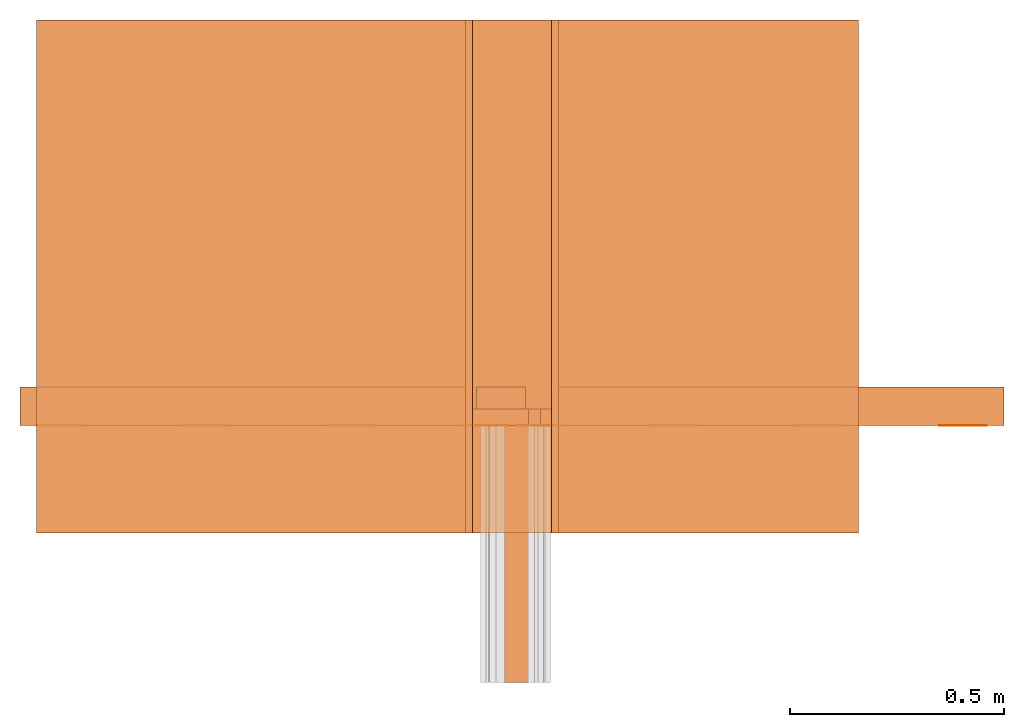
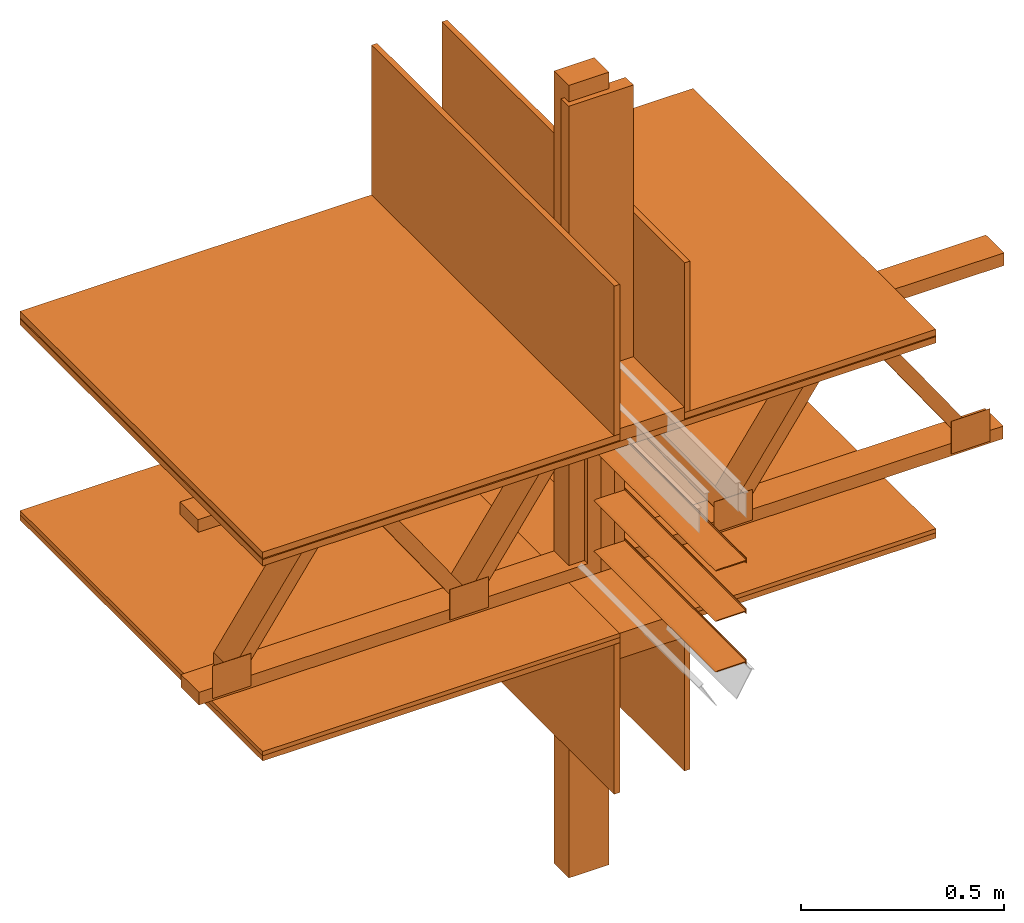
# One storey, part 1 of 2: 17 proxies.
"""IFC2X3 building model written with IfcOpenShell, lengths in metres."""

import ifcopenshell
import ifcopenshell.guid

model = None  # the IFC model being written
_history = None  # IfcOwnerHistory: only IFC2X3 demands one
_inside = {}  # id of a spatial element -> (the spatial element, [elements in it])
_under = {}  # id of a project, library or spatial element -> (it, [spatial elements below it])
_declared = {}  # id of a project -> (the project, [libraries it declares])
_typed = {}  # id of a type object -> (the type object, [elements of that type])
_made_of = {}  # id of a material, layer set ... -> (it, [elements and type objects made of it])


def new_model(schema):
    """Start an empty IFC model of exactly this schema.

    Asked for "IFC4X3", IfcOpenShell would pick the latest addendum, in which some entities
    have other attributes; the version numbers below select the first issue.
    IFC2X3 requires an IfcOwnerHistory on every rooted entity: one is made here for all.
    """
    global model, _history
    if schema == "IFC4X3":
        model = ifcopenshell.file(schema_version=(4, 3, 0, 0))
    else:
        model = ifcopenshell.file(schema=schema)
    _inside.clear()
    _under.clear()
    _declared.clear()
    _typed.clear()
    _made_of.clear()
    _history = None
    if model.schema == "IFC2X3":
        org = make("IfcOrganization", Name="unknown")
        user = make(
            "IfcPersonAndOrganization",
            ThePerson=make("IfcPerson", FamilyName="unknown"),
            TheOrganization=org,
        )
        app = make(
            "IfcApplication",
            ApplicationDeveloper=org,
            Version="unknown",
            ApplicationFullName="unknown",
            ApplicationIdentifier="unknown",
        )
        _history = make(
            "IfcOwnerHistory",
            OwningUser=user,
            OwningApplication=app,
            ChangeAction="ADDED",
            CreationDate=0,
        )
    return model


def make(cls, **values):
    """One entity of the class cls with the attributes given. An attribute that is None is left unset."""
    return model.create_entity(
        cls, **{name: value for name, value in values.items() if value is not None}
    )


def rooted(cls, **values):
    """An entity with a GlobalId (a new one), such as an element, a storey or a relation."""
    return make(cls, GlobalId=ifcopenshell.guid.new(), OwnerHistory=_history, **values)


def si_unit(unit_type, name, prefix=None):
    """IfcSIUnit, for example si_unit("LENGTHUNIT", "METRE", prefix="MILLI")."""
    return make("IfcSIUnit", UnitType=unit_type, Prefix=prefix, Name=name)


def assignment(units):
    """IfcUnitAssignment: the units of a project."""
    return None if units is None else make("IfcUnitAssignment", Units=units)


def point(xyz):
    """IfcCartesianPoint."""
    return None if xyz is None else make("IfcCartesianPoint", Coordinates=xyz)


def direction(xyz):
    """IfcDirection."""
    return None if xyz is None else make("IfcDirection", DirectionRatios=xyz)


def frame(location, z_axis=None, x_axis=None):
    """IfcAxis2Placement3D, a coordinate frame: its origin and axes. An axis left out is left unset."""
    return make(
        "IfcAxis2Placement3D",
        Location=point(location),
        Axis=direction(z_axis),
        RefDirection=direction(x_axis),
    )


def frame_2d(location, x_axis=None):
    """IfcAxis2Placement2D, a coordinate frame in the plane: its origin and x axis."""
    return make(
        "IfcAxis2Placement2D", Location=point(location), RefDirection=direction(x_axis)
    )


def origin_with_axes():
    """The frame at (0, 0, 0) with the z axis (0, 0, 1) and the x axis (1, 0, 0) written out."""
    return frame((0.0, 0.0, 0.0), z_axis=(0.0, 0.0, 1.0), x_axis=(1.0, 0.0, 0.0))


def place(relative_to, where):
    """IfcLocalPlacement: puts the frame where relative to a parent placement (None: the world)."""
    return make(
        "IfcLocalPlacement", PlacementRelTo=relative_to, RelativePlacement=where
    )


def context(
    kind, dimensions, precision=None, world=None, true_north=None, identifier=None
):
    """IfcGeometricRepresentationContext, for example the 3D "Model" context."""
    return make(
        "IfcGeometricRepresentationContext",
        ContextIdentifier=identifier,
        ContextType=kind,
        CoordinateSpaceDimension=dimensions,
        Precision=precision,
        WorldCoordinateSystem=world,
        TrueNorth=true_north,
    )


def subcontext(parent, identifier, kind, view, scale=None):
    """IfcGeometricRepresentationSubContext, for example "Body" below "Model"."""
    return make(
        "IfcGeometricRepresentationSubContext",
        ContextIdentifier=identifier,
        ContextType=kind,
        ParentContext=parent,
        TargetScale=scale,
        TargetView=view,
    )


def project(units=None, contexts=None):
    """IfcProject with its units and contexts."""
    return rooted(
        "IfcProject",
        Name="project",
        RepresentationContexts=contexts,
        UnitsInContext=assignment(units),
    )


def spatial(cls, under=None, at=None, **own):
    """A site, building, storey or space (cls), placed at a placement, below another one or the project."""
    s = rooted(cls, ObjectPlacement=at, **own)
    if under is not None:
        _under.setdefault(under.id(), (under, []))[1].append(s)
    return s


def faces_of(points, faces, orient=None, outer=None):
    """IfcFace entities. A face is a list of loops; a loop is a list of indices into points, from 0.

    orient and outer hold one flag for each loop. By default every Orientation is true, the
    first loop of a face is its IfcFaceOuterBound and the others are IfcFaceBound.
    """
    made = []
    for i, loops in enumerate(faces):
        bounds = []
        for j, loop in enumerate(loops):
            is_outer = j == 0 if outer is None else outer[i][j]
            bounds.append(
                make(
                    "IfcFaceOuterBound" if is_outer else "IfcFaceBound",
                    Bound=make("IfcPolyLoop", Polygon=[points[k] for k in loop]),
                    Orientation=True if orient is None else orient[i][j],
                )
            )
        made.append(make("IfcFace", Bounds=bounds))
    return made


def faceted_brep(points, faces, orient=None, outer=None, voids=None):
    """IfcFacetedBrep: a solid bounded by flat faces; with voids (closed shells), ...WithVoids."""
    shared = [point(p) for p in points]
    hull = make("IfcClosedShell", CfsFaces=faces_of(shared, faces, orient, outer))
    if voids is None:
        return make("IfcFacetedBrep", Outer=hull)
    return make(
        "IfcFacetedBrepWithVoids",
        Outer=hull,
        Voids=[
            make(cls, CfsFaces=faces_of(shared, fs, o, b)) for cls, fs, o, b in voids
        ],
    )


def shape(context_of_items, identifier, shape_type, items):
    """IfcShapeRepresentation: the items that make up one representation, for example the "Body"."""
    return make(
        "IfcShapeRepresentation",
        ContextOfItems=context_of_items,
        RepresentationIdentifier=identifier,
        RepresentationType=shape_type,
        Items=items,
    )


def made_of(thing, what):
    """Note that an element or type object is made of a material, layer set ...; save() writes the relation."""
    if what is not None:
        _made_of.setdefault(what.id(), (what, []))[1].append(thing)
    return thing


def element(
    cls,
    number,
    at=None,
    inside=None,
    cuts=None,
    type_object=None,
    material=None,
    context=None,
    identifier="Body",
    shape_type=None,
    held_by="IfcProductDefinitionShape",
    body=None,
    shapes=None,
    **own,
):
    """One element of the class cls, such as IfcWall. Its Tag is "e" and its number.

    at: its placement. inside: the storey or other place that contains it. cuts: it is an
    opening in that element (IfcRelVoidsElement). A single representation is given by context,
    identifier, shape_type and body (its items); several are given by shapes. held_by: the class
    of the entity that holds the representations. save() writes the other relations.
    """
    e = rooted(cls, Tag="e%d" % number, ObjectPlacement=at, **own)
    if body is not None:
        shapes = [shape(context, identifier, shape_type, body)]
    if shapes is not None:
        e.Representation = make(held_by, Representations=shapes)
    if inside is not None:
        _inside.setdefault(inside.id(), (inside, []))[1].append(e)
    if cuts is not None:
        rooted(
            "IfcRelVoidsElement", RelatingBuildingElement=cuts, RelatedOpeningElement=e
        )
    if type_object is not None:
        _typed.setdefault(type_object.id(), (type_object, []))[1].append(e)
    return made_of(e, material)


def aggregate(whole, parts):
    """IfcRelAggregates: a whole, such as a stair, and the parts it consists of."""
    return rooted("IfcRelAggregates", RelatingObject=whole, RelatedObjects=parts)


def save(model, path):
    """Write the relations noted so far, then the file.

    IfcRelAggregates (storeys below a building ...), IfcRelContainedInSpatialStructure (elements
    in a storey), IfcRelDefinesByType, IfcRelAssociatesMaterial and IfcRelDeclares: one each for
    every whole, place, type object, material and project.
    """
    for whole, parts in _under.values():
        aggregate(whole, parts)
    for where, things in _inside.values():
        rooted(
            "IfcRelContainedInSpatialStructure",
            RelatedElements=things,
            RelatingStructure=where,
        )
    for kind, things in _typed.values():
        rooted("IfcRelDefinesByType", RelatedObjects=things, RelatingType=kind)
    for what, things in _made_of.values():
        rooted("IfcRelAssociatesMaterial", RelatedObjects=things, RelatingMaterial=what)
    for by, libraries in _declared.values():
        rooted("IfcRelDeclares", RelatingContext=by, RelatedDefinitions=libraries)
    model.write(path)


model = new_model("IFC2X3")

# Units and contexts
model_context = context("Model", 3, precision=1e-05, world=origin_with_axes())
plan_context = context("Plan", 2, precision=1e-05, world=frame_2d((0.0, 0.0, 0.0), x_axis=(1.0, 0.0, 0.0)))
body_context = subcontext(model_context, "Body", "Model", "MODEL_VIEW")
ifc_project = project(units=[si_unit("AREAUNIT", "SQUARE_METRE"), si_unit("VOLUMEUNIT", "CUBIC_METRE"), si_unit("LENGTHUNIT", "METRE")], contexts=[model_context, plan_context])

# Site, building, storey
site_placement = place(None, origin_with_axes())
site = spatial("IfcSite", under=ifc_project, at=site_placement, CompositionType="ELEMENT")
building_placement = place(site_placement, origin_with_axes())
building = spatial("IfcBuilding", under=site, at=building_placement, Name="Building", CompositionType="ELEMENT")
storey_placement = place(building_placement, origin_with_axes())
storey = spatial("IfcBuildingStorey", under=building, at=storey_placement, Name="Storey", CompositionType="ELEMENT")

# Proxies
proxy_1_placement = place(storey_placement, frame((1.87213277816772, 0.454421997070312, -0.0896223783493042), z_axis=(0.0, 0.0, 1.0), x_axis=(1.0, 0.0, 0.0)))
element("IfcBuildingElementProxy", 1, at=proxy_1_placement, inside=storey, Name="Generic Models 840:Generic Models 1:245", context=body_context, shape_type="Brep", body=[
    faceted_brep([(0.0, 0.0725396424531937, 2.38604950904846), (0.0, 0.0725396424531937, 0.0), (0.0, 1.52378110129803e-14, 0.0), (0.0, 1.52378110129803e-14, 2.38604950904846), (0.11429999768734, 1.52378110129803e-14, 0.0), (0.11429999768734, 0.0725396424531937, 0.0), (0.11429999768734, 1.52378110129803e-14, 2.38604950904846), (0.11429999768734, 0.0725396424531937, 2.38604950904846)], [[[0, 1, 2, 3]], [[4, 2, 1, 5]], [[3, 2, 4, 6]], [[0, 7, 5, 1]], [[3, 6, 7, 0]], [[4, 5, 7, 6]]]),
])
proxy_2_placement = place(storey_placement, frame((0.845521450042725, 0.18644905090332, 1.37181675434113), z_axis=(0.0, 0.0, 1.0), x_axis=(1.0, 0.0, 0.0)))
element("IfcBuildingElementProxy", 2, at=proxy_2_placement, inside=storey, Name="Generic Models 841:Generic Models 1:245", context=body_context, shape_type="Brep", body=[
    faceted_brep([(-1.44328982613359e-15, 1.19659399986267, 0.0190500002354383), (-1.44328982613359e-15, 1.19659399986267, 0.0), (-1.44328982613359e-15, 3.10862446895044e-15, 0.0), (-1.44328982613359e-15, 3.10862446895044e-15, 0.0190500002354383), (1.91697382926941, 3.10862446895044e-15, 0.0), (1.91697382926941, 1.19659399986267, 0.0), (1.91697382926941, 3.10862446895044e-15, 0.0190500002354383), (1.91697382926941, 1.19659399986267, 0.0190500002354383)], [[[0, 1, 2, 3]], [[4, 2, 1, 5]], [[3, 2, 4, 6]], [[0, 7, 5, 1]], [[3, 6, 7, 0]], [[6, 4, 5, 7]]]),
])
proxy_3_placement = place(storey_placement, frame((1.8625807762146, 0.43806266784668, 1.42896664142609), z_axis=(0.0, 0.0, 1.0), x_axis=(1.0, 0.0, 0.0)))
element("IfcBuildingElementProxy", 3, at=proxy_3_placement, inside=storey, Name="Generic Models 842:Generic Models 1:245", context=body_context, shape_type="Brep", body=[
    faceted_brep([(3.47638584585752e-14, 0.0381000004708767, 0.0), (3.47638584585752e-14, 1.76941794549634e-15, 0.0), (3.47638584585752e-14, 1.76941794549634e-15, 0.817955911159515), (3.47638584585752e-14, 0.0381000004708767, 0.817955911159515), (0.184149980545044, 1.76941794549634e-15, 0.0), (0.184149980545044, 0.0381000004708767, 0.0), (0.184149980545044, 1.76941794549634e-15, 0.817955911159515), (0.184149980545044, 0.0381000004708767, 0.817955911159515)], [[[0, 1, 2, 3]], [[4, 1, 0, 5]], [[2, 1, 4, 6]], [[7, 5, 0, 3]], [[2, 6, 7, 3]], [[4, 5, 7, 6]]]),
])
proxy_4_placement = place(storey_placement, frame((1.8625807762146, 0.18644905090332, 1.39086735248566), z_axis=(0.0, 0.0, 1.0), x_axis=(-1.62920684942947e-07, 1.0, 0.0)))
element("IfcBuildingElementProxy", 4, at=proxy_4_placement, inside=storey, Name="Generic Models 843:Generic Models 1:245", context=body_context, shape_type="Brep", body=[
    faceted_brep([(1.19659399986267, -3.47638584585752e-14, 0.0381000004708767), (1.19659399986267, -3.47638584585752e-14, 0.0), (1.44328982613359e-15, -3.47638584585752e-14, 0.0), (1.44328982613359e-15, -3.47638584585752e-14, 0.0381000004708767), (1.19659399986267, -0.184149980545044, 0.0381000004708767), (1.19659399986267, -0.184149980545044, 0.0), (1.44328982613359e-15, -0.184149980545044, 0.0), (1.44328982613359e-15, -0.184149980545044, 0.0381000004708767)], [[[0, 1, 2, 3]], [[4, 5, 1, 0]], [[3, 2, 6, 7]], [[7, 4, 0, 3]], [[2, 1, 5, 6]], [[7, 6, 5, 4]]]),
])
proxy_5_placement = place(storey_placement, frame((1.9631667137146, 0.437217712402344, 0.819366574287415), z_axis=(0.0, 0.0, 1.0), x_axis=(1.0, 0.0, 0.0)))
element("IfcBuildingElementProxy", 5, at=proxy_5_placement, inside=storey, Name="Generic Models 844:Generic Models 1:245", context=body_context, shape_type="Brep", body=[
    faceted_brep([(-1.52655679120849e-16, 4.05437402400954e-16, 0.54610002040863), (0.110011510550976, 4.05437402400954e-16, 0.54610002040863), (0.110011510550976, 0.000844365218654275, 0.54610002040863), (-1.52655679120849e-16, 0.000844365218654275, 0.54610002040863), (-1.52655679120849e-16, 0.000844365218654275, 0.45427468419075), (-1.52655679120849e-16, 4.05437402400954e-16, 0.45427468419075), (0.42253166437149, 1.48741696043286e-15, 0.0), (0.42253166437149, 0.000844365218654275, 0.0), (0.42253166437149, 0.000844365218654275, 0.0918253213167191), (0.42253166437149, 1.48741696043286e-15, 0.0918253213167191), (0.988360464572906, 0.000844365218654275, 0.0981753244996071), (1.09837198257446, 0.000844365218654275, 0.0981753244996071), (1.09837198257446, 0.000844365218654275, 0.0), (0.988360464572906, 0.000844365218654275, 0.0), (1.09837198257446, 3.65457447290551e-15, 0.0), (0.988360464572906, 3.65457447290551e-15, 0.0), (0.312520146369934, 0.000844365218654275, 0.0), (0.312520146369934, 0.000844365218654275, 0.0918253213167191), (0.988360464572906, 3.65457447290551e-15, 0.0981753244996071), (1.09837198257446, 3.65457447290551e-15, 0.0981753244996071), (0.312520146369934, 1.48741696043286e-15, 0.0), (0.312520146369934, 1.48741696043286e-15, 0.0918253213167191), (0.650440335273743, 2.57254091652322e-15, 0.54610002040863), (0.650440335273743, 2.57254091652322e-15, 0.45427468419075), (0.760451853275299, 2.57254091652322e-15, 0.45427468419075), (0.760451853275299, 2.57254091652322e-15, 0.54610002040863), (0.650440335273743, 0.000844365218654275, 0.54610002040863), (0.650440335273743, 0.000844365218654275, 0.45427468419075), (0.110011510550976, 4.05437402400954e-16, 0.45427468419075), (0.110011510550976, 0.000844365218654275, 0.45427468419075), (0.760451853275299, 0.000844365218654275, 0.54610002040863), (0.760451853275299, 0.000844365218654275, 0.45427468419075)], [[[0, 1, 2, 3]], [[4, 5, 0, 3]], [[6, 7, 8, 9]], [[10, 11, 12, 13]], [[14, 15, 13, 12]], [[8, 7, 16, 17]], [[18, 19, 11, 10]], [[17, 16, 20, 21]], [[6, 20, 16, 7]], [[22, 23, 24, 25]], [[26, 27, 23, 22]], [[28, 29, 2, 1]], [[22, 25, 30, 26]], [[13, 15, 18, 10]], [[24, 23, 27, 31]], [[2, 29, 4, 3]], [[19, 18, 15, 14]], [[30, 31, 27, 26]], [[21, 9, 8, 17]], [[28, 5, 4, 29]], [[21, 20, 6, 9]], [[19, 14, 12, 11]], [[0, 5, 28, 1]], [[24, 31, 30, 25]]]),
])
proxy_6_placement = place(storey_placement, frame((1.8467116355896, 0.18644905090332, 0.333767056465149), z_axis=(0.0, 0.0, 1.0), x_axis=(-1.62920684942947e-07, 1.0, 0.0)))
element("IfcBuildingElementProxy", 6, at=proxy_6_placement, inside=storey, Name="Generic Models 845:Generic Models 1:245", context=body_context, shape_type="Brep", body=[
    faceted_brep([(1.44328982613359e-15, 3.46406930917809e-14, 0.450674533843994), (1.44328982613359e-15, -0.0158750005066395, 0.450674533843994), (1.19659399986267, -0.0158750005066395, 0.450674533843994), (1.19659399986267, 3.46406930917809e-14, 0.450674533843994), (1.44328982613359e-15, -0.200025007128716, 0.450674533843994), (1.44328982613359e-15, -0.200025007128716, 0.0), (1.44328982613359e-15, -0.215900018811226, 0.0), (1.44328982613359e-15, -0.215900018811226, 0.450674533843994), (1.19659399986267, -0.215900018811226, 0.0), (1.19659399986267, -0.215900018811226, 0.450674533843994), (1.19659399986267, 3.46406930917809e-14, 0.0), (1.44328982613359e-15, 3.46406930917809e-14, 0.0), (1.19659399986267, -0.0158750005066395, 0.0), (1.44328982613359e-15, -0.0158750005066395, 0.0), (1.19659399986267, -0.200025007128716, 0.450674533843994), (1.19659399986267, -0.200025007128716, 0.0)], [[[0, 1, 2, 3]], [[4, 5, 6, 7]], [[7, 6, 8, 9]], [[3, 10, 11, 0]], [[11, 10, 12, 13]], [[12, 10, 3, 2]], [[4, 7, 9, 14]], [[9, 8, 15, 14]], [[5, 15, 8, 6]], [[14, 15, 5, 4]], [[0, 11, 13, 1]], [[1, 13, 12, 2]]]),
])
proxy_7_placement = place(storey_placement, frame((1.95468282699585, 0.43806266784668, 0.813017010688782), z_axis=(0.0, 0.0, 1.0), x_axis=(1.0, 0.0, 0.0)))
element("IfcBuildingElementProxy", 7, at=proxy_7_placement, inside=storey, Name="Generic Models 846:Generic Models 1:245", context=body_context, shape_type="Brep", body=[
    faceted_brep([(0.352764397859573, 0.0888999998569489, 0.0381000004708767), (0.376020193099976, 0.0888999998569489, 0.0381000004708767), (0.376020193099976, 0.0, 0.0381000004708767), (0.352764397859573, 0.0, 0.0381000004708767), (0.0, 0.0888999998569489, 0.520699977874756), (0.0, 0.0888999998569489, 0.558799982070923), (1.14725124835968, 0.0888999998569489, 0.558799982070923), (1.14725124835968, 0.0888999998569489, 0.520699977874756), (0.376020193099976, 0.0888999998569489, 0.0713126584887505), (0.376020193099976, 0.0, 0.0713126584887505), (0.0, 0.0888999998569489, 0.0381000004708767), (0.0, 0.0, 0.0381000004708767), (0.0, 0.0, 0.520699977874756), (0.737196087837219, 0.0888999998569489, 0.520699977874756), (0.713940382003784, 0.0888999998569489, 0.520699977874756), (0.713940382003784, 0.0, 0.520699977874756), (0.737196087837219, 0.0, 0.520699977874756), (0.0, 0.0888999998569489, 0.0), (0.0, 0.0, 0.0), (1.14496624469757, 0.0, 0.0), (1.14496624469757, 0.0, 0.0381000004708767), (0.713940382003784, 0.0888999998569489, 0.487487345933914), (0.713940382003784, 0.0, 0.487487345933914), (1.02860474586487, 0.0888999998569489, 0.0381000004708767), (1.02860474586487, 0.0, 0.0381000004708767), (0.0381000004708767, 0.0888999998569489, 0.0381000004708767), (0.0381000004708767, 0.0, 0.0381000004708767), (0.0381000004708767, 0.0888999998569489, 0.520699977874756), (0.0381000004708767, 0.0, 0.520699977874756), (0.0613557584583759, 0.0, 0.520699977874756), (0.0613557584583759, 0.0888999998569489, 0.520699977874756), (0.69068455696106, 0.0888999998569489, 0.520699977874756), (0.69068455696106, 0.0, 0.520699977874756), (1.0518604516983, 0.0888999998569489, 0.0381000004708767), (1.0518604516983, 0.0, 0.0381000004708767), (1.0518604516983, 0.0, 0.0713126584887505), (1.14725124835968, 0.0, 0.558799982070923), (1.14725124835968, 0.0, 0.520699977874756), (0.399275928735733, 0.0888999998569489, 0.0381000004708767), (0.399275928735733, 0.0, 0.0381000004708767), (0.0381000004708767, 0.0, 0.487487345933914), (0.0381000004708767, 0.0888999998569489, 0.487487345933914), (0.0, 0.0, 0.558799982070923), (1.0518604516983, 0.0888999998569489, 0.0713126584887505), (1.14496624469757, 0.0888999998569489, 0.0381000004708767), (1.14496624469757, 0.0888999998569489, 0.0)], [[[0, 1, 2, 3]], [[4, 5, 6, 7]], [[8, 1, 2, 9]], [[4, 10, 11, 12]], [[13, 14, 15, 16]], [[10, 17, 18, 11]], [[11, 18, 19, 20]], [[14, 21, 22, 15]], [[21, 23, 24, 22]], [[10, 25, 26, 11]], [[25, 27, 28, 26]], [[29, 30, 27, 28]], [[31, 8, 9, 32]], [[29, 9, 8, 30]], [[23, 33, 34, 24]], [[14, 31, 32, 15]], [[22, 16, 15]], [[34, 35, 24]], [[7, 6, 36, 37]], [[27, 4, 12, 28]], [[38, 21, 22, 39]], [[40, 29, 28]], [[0, 41, 30, 8]], [[2, 9, 3]], [[36, 6, 5, 42]], [[41, 0, 3, 40]], [[22, 15, 32]], [[3, 9, 29, 40]], [[39, 9, 2]], [[1, 38, 39, 2]], [[21, 14, 13]], [[24, 35, 16, 22]], [[33, 23, 43]], [[27, 41, 40, 28]], [[44, 10, 11, 20]], [[27, 25, 10, 4]], [[8, 38, 1]], [[39, 22, 32, 9]], [[14, 21, 31]], [[45, 44, 20, 19]], [[17, 45, 19, 18]], [[41, 27, 30]], [[23, 21, 13, 43]], [[1, 0, 8]], [[26, 28, 12, 11]], [[33, 43, 35, 34]], [[17, 10, 44, 45]], [[5, 4, 12, 42]], [[4, 7, 37, 12]], [[31, 21, 38, 8]], [[42, 12, 37, 36]], [[43, 13, 16, 35]]]),
])
proxy_8_placement = place(storey_placement, frame((0.845521450042725, 0.18644905090332, 0.784443020820618), z_axis=(0.0, 0.0, 1.0), x_axis=(1.0, 0.0, 0.0)))
element("IfcBuildingElementProxy", 8, at=proxy_8_placement, inside=storey, Name="Generic Models 847:Generic Models 1:245", context=body_context, shape_type="Brep", body=[
    faceted_brep([(1.91697382926941, 1.44328982613359e-15, 0.0158750005066395), (1.20122623443604, 1.44328982613359e-15, 0.0158750005066395), (1.20122623443604, 1.44328982613359e-15, 0.0), (1.91697382926941, 1.44328982613359e-15, 0.0), (1.01707625389099, 1.44328982613359e-15, 0.0158750005066395), (1.01707625389099, 1.19659399986267, 0.0158750005066395), (0.0, 1.19659399986267, 0.0158750005066395), (0.0, 1.44328982613359e-15, 0.0158750005066395), (1.20122623443604, 1.19659399986267, 0.0), (1.91697382926941, 1.19659399986267, 0.0), (1.91697382926941, 1.19659399986267, 0.0158750005066395), (1.20122623443604, 1.19659399986267, 0.0158750005066395), (1.01707625389099, 1.44328982613359e-15, 0.0), (1.01707625389099, 1.19659399986267, 0.0), (0.0, 1.44328982613359e-15, 0.0), (0.0, 1.19659399986267, 0.0)], [[[0, 1, 2, 3]], [[4, 5, 6, 7]], [[3, 2, 8, 9]], [[10, 9, 8, 11]], [[3, 9, 10, 0]], [[12, 13, 5, 4]], [[12, 14, 15, 13]], [[5, 13, 15, 6]], [[1, 0, 10, 11]], [[8, 2, 1, 11]], [[6, 15, 14, 7]], [[7, 14, 12, 4]]]),
])
proxy_9_placement = place(storey_placement, frame((0.845521450042725, 0.18644905090332, 1.39404308795929), z_axis=(0.0, 0.0, 1.0), x_axis=(1.0, 0.0, 0.0)))
element("IfcBuildingElementProxy", 9, at=proxy_9_placement, inside=storey, Name="Generic Models 848:Generic Models 1:245", context=body_context, shape_type="Brep", body=[
    faceted_brep([(1.20122623443604, 1.44328982613359e-15, 0.0190500002354383), (1.20122623443604, 1.44328982613359e-15, 0.0), (1.91697382926941, 1.44328982613359e-15, 0.0), (1.91697382926941, 1.44328982613359e-15, 0.0190500002354383), (0.0, 1.44328982613359e-15, 0.0190500002354383), (1.01707625389099, 1.44328982613359e-15, 0.0190500002354383), (1.01707625389099, 1.19659399986267, 0.0190500002354383), (0.0, 1.19659399986267, 0.0190500002354383), (1.01707625389099, 1.44328982613359e-15, 0.0), (1.01707625389099, 1.19659399986267, 0.0), (1.20122623443604, 1.19659399986267, 0.0), (1.91697382926941, 1.19659399986267, 0.0), (1.91697382926941, 1.19659399986267, 0.0190500002354383), (1.20122623443604, 1.19659399986267, 0.0190500002354383), (0.0, 1.44328982613359e-15, 0.0), (0.0, 1.19659399986267, 0.0)], [[[0, 1, 2, 3]], [[4, 5, 6, 7]], [[5, 8, 9, 6]], [[2, 1, 10, 11]], [[3, 2, 11, 12]], [[12, 11, 10, 13]], [[8, 14, 15, 9]], [[0, 3, 12, 13]], [[13, 10, 1, 0]], [[6, 9, 15, 7]], [[7, 15, 14, 4]], [[4, 14, 8, 5]]]),
])
proxy_10_placement = place(storey_placement, frame((0.845521450042725, 0.18644905090332, 1.39086735248566), z_axis=(0.0, 0.0, 1.0), x_axis=(1.0, 0.0, 0.0)))
element("IfcBuildingElementProxy", 10, at=proxy_10_placement, inside=storey, Name="Generic Models 849:Generic Models 1:245", context=body_context, shape_type="Brep", body=[
    faceted_brep([(1.20122623443604, 1.44328982613359e-15, 0.00317500019446015), (1.20122623443604, 1.44328982613359e-15, 0.0), (1.91697382926941, 1.44328982613359e-15, 0.0), (1.91697382926941, 1.44328982613359e-15, 0.00317500019446015), (0.0, 1.44328982613359e-15, 0.00317500019446015), (1.01707625389099, 1.44328982613359e-15, 0.00317500019446015), (1.01707625389099, 1.19659399986267, 0.00317500019446015), (0.0, 1.19659399986267, 0.00317500019446015), (1.01707625389099, 1.44328982613359e-15, 0.0), (1.01707625389099, 1.19659399986267, 0.0), (1.20122623443604, 1.19659399986267, 0.0), (1.91697382926941, 1.19659399986267, 0.0), (1.91697382926941, 1.19659399986267, 0.00317500019446015), (1.20122623443604, 1.19659399986267, 0.00317500019446015), (0.0, 1.44328982613359e-15, 0.0), (0.0, 1.19659399986267, 0.0)], [[[0, 1, 2, 3]], [[4, 5, 6, 7]], [[5, 8, 9, 6]], [[2, 1, 10, 11]], [[2, 11, 12, 3]], [[12, 11, 10, 13]], [[8, 14, 15, 9]], [[0, 3, 12, 13]], [[13, 10, 1, 0]], [[6, 9, 15, 7]], [[7, 15, 14, 4]], [[4, 14, 8, 5]]]),
])
proxy_11_placement = place(storey_placement, frame((0.845521450042725, 0.18644905090332, 0.800317883491516), z_axis=(0.0, 0.0, 1.0), x_axis=(1.0, 0.0, 0.0)))
element("IfcBuildingElementProxy", 11, at=proxy_11_placement, inside=storey, Name="Generic Models 850:Generic Models 1:245", context=body_context, shape_type="Brep", body=[
    faceted_brep([(0.0, 1.44328982613359e-15, 0.0127000007778406), (0.0, 1.44328982613359e-15, 0.0), (1.01707625389099, 1.44328982613359e-15, 0.0), (1.01707625389099, 1.44328982613359e-15, 0.0127000007778406), (1.20122623443604, 1.44328982613359e-15, 0.0127000007778406), (1.91697382926941, 1.44328982613359e-15, 0.0127000007778406), (1.91697382926941, 1.19659399986267, 0.0127000007778406), (1.20122623443604, 1.19659399986267, 0.0127000007778406), (1.91697382926941, 1.44328982613359e-15, 0.0), (1.91697382926941, 1.19659399986267, 0.0), (0.0, 1.19659399986267, 0.0), (1.01707625389099, 1.19659399986267, 0.0), (1.01707625389099, 1.19659399986267, 0.0127000007778406), (0.0, 1.19659399986267, 0.0127000007778406), (1.20122623443604, 1.44328982613359e-15, 0.0), (1.20122623443604, 1.19659399986267, 0.0)], [[[0, 1, 2, 3]], [[4, 5, 6, 7]], [[5, 8, 9, 6]], [[2, 1, 10, 11]], [[3, 2, 11, 12]], [[12, 11, 10, 13]], [[8, 14, 15, 9]], [[0, 3, 12, 13]], [[13, 10, 1, 0]], [[6, 9, 15, 7]], [[7, 15, 14, 4]], [[4, 14, 8, 5]]]),
])
proxy_12_placement = place(storey_placement, frame((1.8467116355896, 0.18644905090332, 1.41309177875519), z_axis=(0.0, 0.0, 1.0), x_axis=(-1.62920684942947e-07, 1.0, 0.0)))
element("IfcBuildingElementProxy", 12, at=proxy_12_placement, inside=storey, Name="Generic Models 851:Generic Models 1:245", context=body_context, shape_type="Brep", body=[
    faceted_brep([(1.44328982613359e-15, 3.46406930917809e-14, 0.0), (1.19659399986267, 3.46406930917809e-14, 0.0), (1.19659399986267, -0.0158750005066395, 0.0), (1.44328982613359e-15, -0.0158750005066395, 0.0), (1.44328982613359e-15, -0.200025007128716, 0.450674533843994), (1.44328982613359e-15, -0.200025007128716, 0.0), (1.44328982613359e-15, -0.215900018811226, 0.0), (1.44328982613359e-15, -0.215900018811226, 0.450674533843994), (1.19659399986267, -0.215900018811226, 0.0), (1.19659399986267, -0.215900018811226, 0.450674533843994), (1.19659399986267, 3.46406930917809e-14, 0.450674533843994), (1.19659399986267, -0.0158750005066395, 0.450674533843994), (1.44328982613359e-15, -0.0158750005066395, 0.450674533843994), (1.44328982613359e-15, 3.46406930917809e-14, 0.450674533843994), (1.19659399986267, -0.200025007128716, 0.450674533843994), (1.19659399986267, -0.200025007128716, 0.0)], [[[0, 1, 2, 3]], [[4, 5, 6, 7]], [[7, 6, 8, 9]], [[2, 1, 10, 11]], [[12, 3, 2, 11]], [[13, 12, 11, 10]], [[14, 15, 5, 4]], [[5, 15, 8, 6]], [[10, 1, 0, 13]], [[13, 0, 3, 12]], [[9, 8, 15, 14]], [[4, 7, 9, 14]]]),
])
proxy_13_placement = place(storey_placement, frame((0.8478102684021, 0.437217712402344, 0.819366574287415), z_axis=(0.0, 0.0, 1.0), x_axis=(1.0, 0.0, 0.0)))
element("IfcBuildingElementProxy", 13, at=proxy_13_placement, inside=storey, Name="Generic Models 852:Generic Models 1:245", context=body_context, shape_type="Brep", body=[
    faceted_brep([(0.988360464572906, 4.05437402400954e-16, 0.54610002040863), (1.09837198257446, 4.05437402400954e-16, 0.54610002040863), (1.09837198257446, 0.000844365218654275, 0.54610002040863), (0.988360464572906, 0.000844365218654275, 0.54610002040863), (0.988360464572906, 0.000844365218654275, 0.45427468419075), (0.988360464572906, 4.05437402400954e-16, 0.45427468419075), (0.110011510550976, 3.52045887592729e-15, 0.0), (2.08028039239139e-13, 3.52045887592729e-15, 0.0), (2.08028039239139e-13, 0.000844365218654275, 0.0), (0.110011510550976, 0.000844365218654275, 0.0), (0.447931677103043, 0.000844365218654275, 0.54610002040863), (0.447931677103043, 0.000844365218654275, 0.45427468419075), (0.337920129299164, 0.000844365218654275, 0.45427468419075), (0.337920129299164, 0.000844365218654275, 0.54610002040863), (0.785851836204529, 1.48741696043286e-15, 0.0), (0.675840258598328, 1.48741696043286e-15, 0.0), (0.675840258598328, 0.000844365218654275, 0.0), (0.785851836204529, 0.000844365218654275, 0.0), (0.675840258598328, 0.000844365218654275, 0.0918253213167191), (0.785851836204529, 0.000844365218654275, 0.0918253213167191), (2.08028039239139e-13, 3.52045887592729e-15, 0.0981753244996071), (0.110011510550976, 3.52045887592729e-15, 0.0981753244996071), (0.110011510550976, 0.000844365218654275, 0.0981753244996071), (2.08028039239139e-13, 0.000844365218654275, 0.0981753244996071), (0.675840258598328, 1.48741696043286e-15, 0.0918253213167191), (0.785851836204529, 1.48741696043286e-15, 0.0918253213167191), (0.337920129299164, 2.57254091652322e-15, 0.54610002040863), (0.337920129299164, 2.57254091652322e-15, 0.45427468419075), (0.447931677103043, 2.57254091652322e-15, 0.45427468419075), (0.447931677103043, 2.57254091652322e-15, 0.54610002040863), (1.09837198257446, 4.05437402400954e-16, 0.45427468419075), (1.09837198257446, 0.000844365218654275, 0.45427468419075)], [[[0, 1, 2, 3]], [[4, 5, 0, 3]], [[6, 7, 8, 9]], [[10, 11, 12, 13]], [[14, 15, 16, 17]], [[18, 19, 17, 16]], [[20, 21, 22, 23]], [[18, 16, 15, 24]], [[25, 19, 18, 24]], [[26, 27, 28, 29]], [[13, 12, 27, 26]], [[0, 5, 30, 1]], [[26, 29, 10, 13]], [[22, 9, 8, 23]], [[21, 20, 7, 6]], [[2, 31, 4, 3]], [[30, 31, 2, 1]], [[25, 14, 17, 19]], [[8, 7, 20, 23]], [[27, 12, 11, 28]], [[24, 15, 14, 25]], [[21, 6, 9, 22]], [[5, 4, 31, 30]], [[28, 11, 10, 29]]]),
])
proxy_14_placement = place(storey_placement, frame((1.99276876449585, 0.43806266784668, 0.851118206977844), z_axis=(0.0, 0.0, 1.0), x_axis=(-1.62920684942947e-07, 1.0, 0.0)))
element("IfcBuildingElementProxy", 14, at=proxy_14_placement, inside=storey, Name="Generic Models 853:Generic Models 1:245", context=body_context, shape_type="Brep", body=[
    faceted_brep([(0.0381000004708767, 0.0, 0.396597027778625), (0.0381000004708767, 0.0, 0.0), (0.0, 0.0, 0.0), (0.0, 0.0, 0.396597027778625), (0.0381000004708767, -0.0285749994218349, 0.0), (0.0381000004708767, -0.0285749994218349, 0.396597027778625), (0.0, -0.0285749994218349, 0.0), (0.0, -0.0285749994218349, 0.396597027778625)], [[[0, 1, 2, 3]], [[4, 1, 0, 5]], [[3, 2, 6, 7]], [[7, 5, 0, 3]], [[2, 1, 4, 6]], [[7, 6, 4, 5]]]),
])
proxy_15_placement = place(storey_placement, frame((1.93380880355835, -0.162212371826172, 0.875089764595032), z_axis=(0.0, 0.0, 1.0), x_axis=(-1.62920684942947e-07, 1.0, 0.0)))
element("IfcBuildingElementProxy", 15, at=proxy_15_placement, inside=storey, Name="Generic Models 854:Generic Models 1:245", context=body_context, shape_type="Brep", body=[
    faceted_brep([(0.0, -0.00712807150557637, 0.00928318779915571), (0.0, 0.0, 0.0073732272721827), (0.0, -0.00406986707821488, 0.00628270907327533), (0.0, -0.0875341817736626, 0.00928318779915571), (0.0, -0.0888999998569489, 0.0147464545443654), (0.0, -0.0875341817736626, 0.0147464545443654), (0.0, -0.0875341817736626, 0.00628270907327533), (0.0, -0.0888999998569489, 0.0), (0.0, -0.0875341817736626, 0.0), (0.600274682044983, -0.0875341817736626, 0.00628270907327533), (0.600274682044983, -0.0875341817736626, 0.0), (0.600274682044983, -0.0875341817736626, 0.00928318779915571), (0.600274682044983, -0.00712807150557637, 0.00928318779915571), (0.600274682044983, -0.0888999998569489, 0.16714645922184), (0.600274682044983, -0.0875341817736626, 0.16714645922184), (0.0, -0.0875341817736626, 0.16714645922184), (0.0, -0.0888999998569489, 0.16714645922184), (0.600274682044983, -0.0875341817736626, 0.314083188772202), (0.600274682044983, -0.00712807150557637, 0.314083188772202), (0.0, -0.00712807150557637, 0.314083188772202), (0.0, -0.0875341817736626, 0.314083188772202), (0.600274682044983, -0.0875341817736626, 0.0147464545443654), (0.600274682044983, -0.0875341817736626, 0.158682703971863), (0.0, -0.0875341817736626, 0.158682703971863), (0.0, -0.00406986707821488, 0.158682703971863), (0.600274682044983, -0.00406986707821488, 0.158682703971863), (0.600274682044983, -0.00406986707821488, 0.311082720756531), (0.600274682044983, -0.0875341817736626, 0.311082720756531), (0.0, -0.0875341817736626, 0.311082720756531), (0.0, -0.00406986707821488, 0.311082720756531), (0.600274682044983, -0.00406986707821488, 0.00628270907327533), (0.600274682044983, 0.0, 0.0073732272721827), (0.600274682044983, -0.0888999998569489, 0.0), (0.600274682044983, -0.0888999998569489, 0.0147464545443654), (0.0, -0.00712807150557637, 0.161683186888695), (0.0, 0.0, 0.159773230552673), (0.0, -0.0875341817736626, 0.161683186888695), (0.0, -0.0888999998569489, 0.152400001883507), (0.0, -0.0875341817736626, 0.152400001883507), (0.600274682044983, -0.0875341817736626, 0.304800003767014), (0.0, -0.0875341817736626, 0.304800003767014), (0.600274682044983, -0.0875341817736626, 0.161683186888695), (0.600274682044983, 0.0, 0.312173217535019), (0.0, 0.0, 0.312173217535019), (0.600274682044983, -0.00712807150557637, 0.161683186888695), (0.600274682044983, 0.0, 0.159773230552673), (0.600274682044983, -0.0888999998569489, 0.152400001883507), (0.600274682044983, -0.0875341817736626, 0.152400001883507), (0.600274682044983, -0.0888999998569489, 0.319546461105347), (0.600274682044983, -0.0875341817736626, 0.319546461105347), (0.0, -0.0875341817736626, 0.319546461105347), (0.0, -0.0888999998569489, 0.319546461105347), (0.600274682044983, -0.0888999998569489, 0.304800003767014), (0.0, -0.0888999998569489, 0.304800003767014)], [[[0, 1, 2]], [[3, 4, 5]], [[6, 3, 0]], [[6, 4, 3]], [[7, 6, 8]], [[7, 4, 6]], [[2, 6, 0]], [[9, 10, 8, 6]], [[3, 11, 12, 0]], [[13, 14, 15, 16]], [[17, 18, 19, 20]], [[21, 11, 3, 5]], [[22, 23, 24, 25]], [[26, 27, 28, 29]], [[12, 30, 31]], [[9, 32, 10]], [[11, 9, 12]], [[33, 11, 21]], [[33, 32, 9]], [[33, 9, 11]], [[9, 30, 12]], [[34, 35, 24]], [[36, 16, 15]], [[23, 36, 34]], [[23, 16, 36]], [[37, 23, 38]], [[37, 16, 23]], [[24, 23, 34]], [[27, 39, 40, 28]], [[14, 41, 36, 15]], [[18, 42, 43, 19]], [[44, 45, 35, 34]], [[44, 25, 45]], [[22, 46, 47]], [[41, 22, 44]], [[13, 41, 14]], [[13, 46, 22]], [[13, 22, 41]], [[22, 25, 44]], [[48, 49, 50, 51]], [[18, 26, 42]], [[27, 52, 39]], [[17, 27, 18]], [[48, 17, 49]], [[48, 52, 27]], [[48, 27, 17]], [[27, 26, 18]], [[52, 48, 51, 53]], [[46, 37, 38, 47]], [[36, 41, 44, 34]], [[32, 33, 4, 7]], [[12, 31, 1, 0]], [[45, 25, 24, 35]], [[19, 43, 29]], [[20, 51, 50]], [[28, 20, 19]], [[28, 51, 20]], [[53, 28, 40]], [[53, 51, 28]], [[29, 28, 19]], [[46, 13, 16, 37]], [[9, 6, 2, 30]], [[42, 26, 29, 43]], [[52, 53, 40, 39]], [[22, 47, 38, 23]], [[49, 17, 20, 50]], [[31, 30, 2, 1]], [[32, 7, 8, 10]], [[33, 21, 5, 4]]]),
])
proxy_16_placement = place(storey_placement, frame((0.8074049949646, 0.43806266784668, 0.813017010688782), z_axis=(0.0, 0.0, 1.0), x_axis=(1.0, 0.0, 0.0)))
element("IfcBuildingElementProxy", 16, at=proxy_16_placement, inside=storey, Name="Generic Models 855:Generic Models 1:245", context=body_context, shape_type="Brep", body=[
    faceted_brep([(0.0, 0.0888999998569489, 0.520699977874756), (0.0, 0.0888999998569489, 0.558799982070923), (1.14725124835968, 0.0888999998569489, 0.558799982070923), (1.14725124835968, 0.0888999998569489, 0.520699977874756), (0.771231055259705, 0.0888999998569489, 0.0381000004708767), (0.771231055259705, 0.0, 0.0381000004708767), (0.771231055259705, 0.0, 0.0713126584887505), (0.771231055259705, 0.0888999998569489, 0.0713126584887505), (0.794486820697784, 0.0888999998569489, 0.0381000004708767), (0.794486820697784, 0.0, 0.0381000004708767), (1.10915124416351, 0.0888999998569489, 0.487487345933914), (1.10915124416351, 0.0, 0.487487345933914), (0.00228500948287547, 0.0888999998569489, 0.0), (1.14725124835968, 0.0888999998569489, 0.0), (1.14725124835968, 0.0, 0.0), (0.00228500948287547, 0.0, 0.0), (1.14725124835968, 0.0, 0.520699977874756), (0.0, 0.0, 0.520699977874756), (0.0953907743096352, 0.0888999998569489, 0.0713126584887505), (0.0953907743096352, 0.0888999998569489, 0.0381000004708767), (0.0953907743096352, 0.0, 0.0381000004708767), (0.0953907743096352, 0.0, 0.0713126584887505), (0.118646524846554, 0.0888999998569489, 0.0381000004708767), (0.118646524846554, 0.0, 0.0381000004708767), (0.00228500948287547, 0.0888999998569489, 0.0381000004708767), (0.00228500948287547, 0.0, 0.0381000004708767), (1.08589553833008, 0.0888999998569489, 0.520699977874756), (1.08589553833008, 0.0, 0.520699977874756), (0.456566691398621, 0.0888999998569489, 0.520699977874756), (0.456566691398621, 0.0, 0.520699977874756), (1.10915124416351, 0.0888999998569489, 0.520699977874756), (1.10915124416351, 0.0, 0.520699977874756), (0.433310955762863, 0.0888999998569489, 0.520699977874756), (0.433310955762863, 0.0, 0.520699977874756), (1.14725124835968, 0.0888999998569489, 0.0381000004708767), (1.14725124835968, 0.0, 0.0381000004708767), (0.433310955762863, 0.0888999998569489, 0.487487345933914), (0.433310955762863, 0.0, 0.487487345933914), (0.74797534942627, 0.0888999998569489, 0.0381000004708767), (0.74797534942627, 0.0, 0.0381000004708767), (1.10915124416351, 0.0888999998569489, 0.0381000004708767), (0.410055160522461, 0.0888999998569489, 0.520699977874756), (0.410055160522461, 0.0, 0.520699977874756), (0.0, 0.0, 0.558799982070923), (1.14725124835968, 0.0, 0.558799982070923), (1.10915124416351, 0.0, 0.0381000004708767)], [[[0, 1, 2, 3]], [[4, 5, 6, 7]], [[4, 8, 9, 5]], [[8, 10, 11, 9]], [[12, 13, 14, 15]], [[0, 3, 16, 17]], [[18, 19, 20, 21]], [[19, 22, 23, 20]], [[24, 12, 15, 25]], [[26, 7, 6, 27]], [[7, 28, 29, 6]], [[30, 26, 27, 31]], [[28, 32, 33, 29]], [[34, 3, 16, 35]], [[36, 37, 33, 32]], [[3, 30, 31, 16]], [[10, 30, 31, 11]], [[37, 29, 33]], [[28, 7, 38, 36]], [[5, 6, 39]], [[40, 30, 3, 34]], [[34, 24, 25, 35]], [[14, 13, 34, 35]], [[32, 41, 42, 33]], [[43, 17, 16, 44]], [[30, 40, 45, 31]], [[36, 38, 39, 37]], [[12, 24, 34, 13]], [[44, 2, 1, 43]], [[37, 33, 42]], [[41, 36, 22, 18]], [[23, 21, 20]], [[25, 15, 14, 35]], [[31, 45, 35, 16]], [[18, 22, 19]], [[8, 7, 26, 10]], [[32, 36, 41]], [[11, 31, 27]], [[39, 6, 29, 37]], [[9, 6, 5]], [[41, 18, 21, 42]], [[7, 4, 38]], [[28, 36, 32]], [[10, 26, 30]], [[9, 11, 27, 6]], [[8, 4, 7]], [[23, 37, 42, 21]], [[1, 0, 17, 43]], [[38, 4, 5, 39]], [[3, 2, 44, 16]], [[22, 36, 37, 23]], [[40, 34, 35, 45]]]),
])
proxy_17_placement = place(storey_placement, frame((1.8625807762146, 0.18644905090332, 0.73681652545929), z_axis=(0.0, 0.0, 1.0), x_axis=(-1.62920684942947e-07, 1.0, 0.0)))
element("IfcBuildingElementProxy", 17, at=proxy_17_placement, inside=storey, Name="Generic Models 857:Generic Models 1:245", context=body_context, shape_type="Brep", body=[
    faceted_brep([(1.44328982613359e-15, -3.47638584585752e-14, 0.0762000009417534), (1.44328982613359e-15, -3.47638584585752e-14, 0.0381000004708767), (1.44328982613359e-15, -0.184149980545044, 0.0381000004708767), (1.44328982613359e-15, -0.184149980545044, 0.0762000009417534), (1.19659399986267, -0.184149980545044, 0.0381000004708767), (1.19659399986267, -3.47638584585752e-14, 0.0381000004708767), (1.44328982613359e-15, -0.184149980545044, 0.0), (1.19659399986267, -0.184149980545044, 0.0), (1.19659399986267, -3.47638584585752e-14, 0.0), (1.44328982613359e-15, -3.47638584585752e-14, 0.0), (1.19659399986267, -0.184149980545044, 0.0762000009417534), (1.19659399986267, -3.47638584585752e-14, 0.0762000009417534)], [[[0, 1, 2, 3]], [[2, 4, 5, 1]], [[2, 6, 7, 4]], [[5, 8, 9, 1]], [[3, 2, 4, 10]], [[3, 10, 11, 0]], [[10, 4, 5, 11]], [[4, 7, 8, 5]], [[9, 8, 7, 6]], [[11, 5, 1, 0]], [[1, 9, 6, 2]]]),
])

save(model, "model.ifc")
